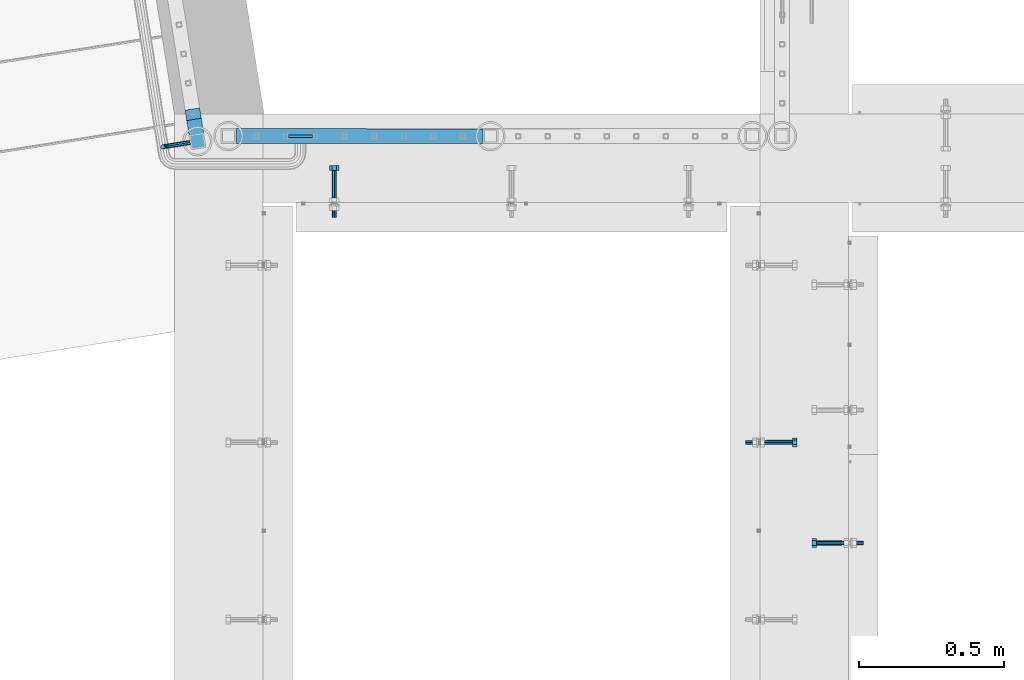
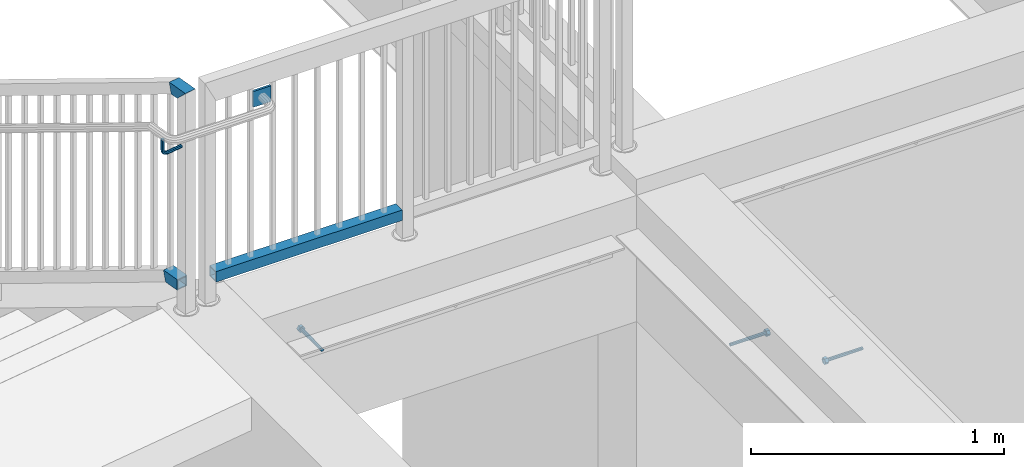
# One storey, part 425 of 975: 8 beams.
"""IFC2X3 building model written with IfcOpenShell, lengths in millimetres."""

from ifc_helpers import new_model, si_unit, frame, origin_with_axes, place, context, subcontext, project, spatial, faceted_brep, material, type_object, element, save


model = new_model("IFC2X3")

# Units and contexts
model_context = context("Model", 3, precision=1e-05, world=origin_with_axes())
body_context = subcontext(model_context, "Body", "Model", "MODEL_VIEW")
ifc_project = project(units=[si_unit("LENGTHUNIT", "METRE", prefix="MILLI"), si_unit("AREAUNIT", "SQUARE_METRE"), si_unit("VOLUMEUNIT", "CUBIC_METRE"), si_unit("MASSUNIT", "GRAM", prefix="KILO"), si_unit("TIMEUNIT", "SECOND"), si_unit("PLANEANGLEUNIT", "RADIAN"), si_unit("SOLIDANGLEUNIT", "STERADIAN"), si_unit("THERMODYNAMICTEMPERATUREUNIT", "DEGREE_CELSIUS"), si_unit("LUMINOUSINTENSITYUNIT", "LUMEN")], contexts=[model_context])

# Site, building, storey
site_placement = place(None, origin_with_axes())
site = spatial("IfcSite", under=ifc_project, at=site_placement, CompositionType="ELEMENT")
building_placement = place(site_placement, origin_with_axes())
building = spatial("IfcBuilding", under=site, at=building_placement, Name="Undefined", CompositionType="ELEMENT")
storey_placement = place(building_placement, origin_with_axes())
storey = spatial("IfcBuildingStorey", under=building, at=storey_placement, Name="Undefined", CompositionType="ELEMENT", Elevation=0.0)

# Beams
ifc_material_1 = material(Name="STEEL/A36")
beam_type_1 = type_object("IfcBeamType", PredefinedType="NOTDEFINED")
beam_1_placement = place(storey_placement, frame((54.8214659139176, 20650.6357570104, 4838.70005627134), z_axis=(0.0, 0.0, 1.0), x_axis=(-0.987688340611262, -0.156434464938429, 0.0)))
element("IfcBeam", 1, at=beam_1_placement, inside=storey, type_object=beam_type_1, material=ifc_material_1, Name="BRACKET", context=body_context, shape_type="Brep", body=[
    faceted_brep([(-4.22995071858168e-07, -7.93750000000728, 0.0), (-2.99107341561466e-07, -5.61266007567065, -5.61266007566792), (69.8503542524265, -5.61266011719636, -5.61266006824098), (69.8503542509172, -7.93750004153844, 7.13935150997713e-08), (-1.09139364212751e-11, 1.81898940354586e-12, -7.9375), (69.8503542548774, -4.15166141465306e-08, -7.93749999257489), (2.99089151667431e-07, 5.61266007567428, -5.61266007566792), (69.850354256834, 5.61266003415949, -5.61266006824462), (4.22980519942939e-07, 7.93750000001091, 0.0), (69.8503542571498, 7.93749995848702, 7.42329575587064e-09), (2.99089151667431e-07, 5.61266007567428, 5.61266007566792), (69.8503542556402, 5.61266003414494, 5.61266008309212), (-1.09139364212751e-11, 1.81898940354586e-12, 7.9375), (69.8503542531901, -4.1531166061759e-08, 7.93750000742511), (-2.99107341561466e-07, -5.61266007567065, 5.61266007566792), (69.8503542512333, -5.61266011720727, 5.61266008309485), (82.6080619660092, -1.59849150804803e-07, -5.39983437818319), (81.7183842570932, -5.61266021300253, -3.25196229146422), (79.5705123886862, -7.93750008296047, 1.9334595635828), (77.422640571061, -5.61266010424515, 7.11888139089478), (76.5329629847436, -6.04632077738643e-09, 9.26675341066039), (77.42264069366, 5.61266004711069, 7.11888132394142), (79.5705125620677, 7.93749991707227, 1.93345946889531), (81.7183843796927, 5.61265993835332, -3.2519623584185), (91.7796148150826, 5.61265980362077, 3.4707361335004), (93.4235246654027, -3.04684363072738e-07, 1.82682594388461), (87.8108651363229, 7.93749980671782, 7.4394864085989), (83.842115365278, 5.61265996114525, 11.4082366836983), (82.1982052921601, -8.1912730820477e-08, 13.0521468733186), (83.8421151424809, -5.61266019021059, 11.4082366837029), (87.8108648212394, -7.93750019330764, 7.43948640860435), (91.7796145922794, -5.61266034773871, 3.47073613349858), (98.5023147018187, 5.61265960524179, 13.5319656369056), (100.650186486849, -5.1793540478684e-07, 12.6422876414272), (93.316893218411, 7.93749964423841, 15.6798382195402), (88.1314716149859, 5.61265983456542, 17.8277107606718), (85.9835995402068, -1.93616870092228e-07, 18.7173886559558), (88.1314713252375, -5.61266031678679, 17.8277106604774), (93.3168928086452, -7.93750035579069, 15.6798380778428), (98.5023144120698, -5.6126605461177, 13.5319655367102), (100.86301410217, 5.61265937340795, 25.399995432489), (103.187853869874, -7.6714059105143e-07, 25.3999950007492), (95.2503540913781, 7.93749945436502, 25.3999962564121), (89.6376939508302, 5.61265968664884, 25.3999969898769), (87.3128538698681, -3.24151187669486e-07, 25.3999972032288), (89.6376936375721, -5.61266046470701, 25.399996771489), (95.2503537123291, -7.93750054566044, 25.3999959475659), (100.863013788912, -5.61266077794789, 25.3999952141021), (100.863020882074, -5.6126617210939, 76.2000018706158), (95.2503607602616, -7.93750153403744, 76.2000026040805), (103.187860917806, -1.69155464391224e-06, 76.2000016572638), (100.863021104872, 5.61265843026558, 76.2000020890027), (95.2503610753454, 7.93749846599167, 76.2000029129267), (89.6377009535329, 5.61265865304449, 76.2000036463905), (87.3128609178009, -1.37649476528168e-06, 76.2000038597416), (89.6377007307347, -5.61266149831135, 76.2000034280036)], [[[0, 1, 2, 3]], [[1, 4, 5, 2]], [[4, 6, 7, 5]], [[6, 8, 9, 7]], [[8, 10, 11, 9]], [[10, 12, 13, 11]], [[12, 14, 15, 13]], [[14, 0, 3, 15]], [[14, 12, 10, 8, 6, 4, 1, 0]], [[2, 5, 16, 17]], [[3, 2, 17, 18]], [[15, 3, 18, 19]], [[13, 15, 19, 20]], [[11, 13, 20, 21]], [[9, 11, 21, 22]], [[7, 9, 22, 23]], [[5, 7, 23, 16]], [[23, 24, 25, 16]], [[22, 26, 24, 23]], [[21, 27, 26, 22]], [[20, 28, 27, 21]], [[19, 29, 28, 20]], [[18, 30, 29, 19]], [[17, 31, 30, 18]], [[16, 25, 31, 17]], [[24, 32, 33, 25]], [[26, 34, 32, 24]], [[27, 35, 34, 26]], [[28, 36, 35, 27]], [[29, 37, 36, 28]], [[30, 38, 37, 29]], [[31, 39, 38, 30]], [[25, 33, 39, 31]], [[32, 40, 41, 33]], [[34, 42, 40, 32]], [[35, 43, 42, 34]], [[36, 44, 43, 35]], [[37, 45, 44, 36]], [[38, 46, 45, 37]], [[39, 47, 46, 38]], [[33, 41, 47, 39]], [[46, 47, 48, 49]], [[47, 41, 50, 48]], [[41, 40, 51, 50]], [[40, 42, 52, 51]], [[42, 43, 53, 52]], [[43, 44, 54, 53]], [[44, 45, 55, 54]], [[45, 46, 49, 55]], [[50, 51, 52, 53, 54, 55, 49, 48]]]),
])
ifc_material_2 = material()
beam_type_2 = type_object("IfcBeamType", Name="HSS2X2X.188_TUBES", PredefinedType="NOTDEFINED")
beam_2_placement = place(storey_placement, frame((186.288332017304, 20672.424971935, 4152.90002239251), z_axis=(4.97069999879329e-05, 0.999999998764607, 0.0), x_axis=(0.999999998764607, -4.97069999879304e-05, -1.40000005822416e-08)))
element("IfcBeam", 2, at=beam_2_placement, inside=storey, type_object=beam_type_2, material=ifc_material_2, Name="HANDRAIL", ObjectType="HSS2X2X.188_TUBES", context=body_context, shape_type="Brep", body=[
    faceted_brep([(25.4010274002821, 20.6374999999962, -20.6374999999789), (25.4010268224347, -20.6375000000035, -20.6375000000444), (876.518362135897, -20.6375000001299, -20.6374999995787), (876.518362755016, 20.6374999998698, -20.6374999996115), (25.3989752050193, -20.6375000000035, 20.6374999999534), (876.516310479488, -20.6375000001299, 20.6375000003572), (25.3989757828676, 20.6374999999971, 20.6375000000226), (876.516311098607, 20.6374999998707, 20.6375000003281), (25.4012641920428, 25.3999999999969, -25.399999999976), (25.3987391244552, 25.399999999996, 25.4000000000306), (876.516074440458, 25.3999999998705, 25.400000000318), (876.518599556039, 25.3999999998705, -25.3999999996086), (25.3987384132577, -25.4000000000042, 25.3999999999505), (876.516073678465, -25.4000000001288, 25.4000000003543), (25.4012634808457, -25.4000000000033, -25.400000000056), (876.518598794046, -25.4000000001297, -25.3999999995722)], [[[0, 1, 2, 3]], [[1, 4, 5, 2]], [[4, 6, 7, 5]], [[6, 0, 3, 7]], [[8, 9, 10, 11]], [[9, 12, 13, 10]], [[12, 14, 15, 13]], [[14, 8, 11, 15]], [[13, 15, 11, 10], [5, 7, 3, 2]], [[14, 12, 9, 8], [6, 4, 1, 0]]]),
])
beam_3_placement = place(storey_placement, frame((79.9089065875678, 20654.6092119886, 4152.89999210174), z_axis=(0.987688352468583, 0.156434390074216, -6.09999983468464e-08), x_axis=(-0.156434502935552, 0.987688334593108, 0.0)))
element("IfcBeam", 3, at=beam_3_placement, inside=storey, type_object=beam_type_2, material=ifc_material_2, Name="HANDRAIL", ObjectType="HSS2X2X.188_TUBES", context=body_context, shape_type="Brep", body=[
    faceted_brep([(25.3999997357314, 20.6374999999898, -20.6374999999998), (25.4000002641624, -20.6375000000153, -20.6374999999998), (100.375736823349, -20.637499999998, -20.6375000000148), (111.012663915226, 20.6375000000016, -20.6375000000157), (25.4000002641624, -20.6375000000153, 20.6374999999998), (100.375737142476, -20.637499999998, 20.6374999999903), (25.3999997357314, 20.6374999999898, 20.6374999999998), (111.012664234357, 20.6375000000016, 20.6374999999894), (25.4000003077635, 25.3999999999942, -25.3999999999996), (25.3999996747552, 25.3999999999905, 25.3999999999996), (112.240002012546, 25.4000000000024, 25.3999999999896), (112.240001619772, 25.4000000000024, -25.400000000016), (25.4000003251349, -25.4000000000124, 25.3999999999996), (99.1483994379269, -25.3999999999987, 25.3999999999901), (25.4000003077854, -25.4000000000087, -25.3999999999996), (99.1483990451525, -25.3999999999987, -25.4000000000146)], [[[0, 1, 2, 3]], [[1, 4, 5, 2]], [[4, 6, 7, 5]], [[6, 0, 3, 7]], [[8, 9, 10, 11]], [[9, 12, 13, 10]], [[12, 14, 15, 13]], [[14, 8, 11, 15]], [[13, 15, 11, 10], [5, 7, 3, 2]], [[14, 12, 9, 8], [6, 4, 1, 0]]]),
])
beam_4_placement = place(storey_placement, frame((79.9089713856818, 20654.6092409208, 5079.99999210166), z_axis=(0.987688199802292, 0.156435353968682, 0.0), x_axis=(-0.156435353968642, 0.987688199802032, 7.25999996843755e-07)))
element("IfcBeam", 4, at=beam_4_placement, inside=storey, type_object=beam_type_2, material=ifc_material_2, Name="HANDRAIL", ObjectType="HSS2X2X.188_TUBES", context=body_context, shape_type="Brep", body=[
    faceted_brep([(-20.6375220683622, 20.6375000000126, -20.6374999999962), (20.6375002484456, -20.637500000008, -20.6374999999998), (64.3357161775057, -20.6375000000317, -20.6374999999998), (74.9726787480031, 20.6374999999744, -20.6374999999898), (20.6374851600922, -20.6375000000144, 20.637499999998), (64.3356988180385, -20.6375000000317, 20.6375000000007), (-20.6375002658751, 20.637500000008, 20.6374999999998), (74.9726613885359, 20.6374999999744, 20.6375000000112), (-25.4000229024168, 25.400000000016, -25.3999999999955), (-25.4000003252186, 25.4000000000087, 25.3999999999996), (76.2000012205863, 25.3999999999751, 25.4000000000128), (76.2000225860793, 25.3999999999751, -25.3999999999887), (25.4000003251349, -25.4000000000124, 25.3999999999996), (63.108354979966, -25.4000000000324, 25.4000000000001), (25.4000003077854, -25.4000000000087, -25.3999999999996), (63.1083763454626, -25.4000000000324, -25.400000000001)], [[[0, 1, 2, 3]], [[1, 4, 5, 2]], [[4, 6, 7, 5]], [[6, 0, 3, 7]], [[8, 9, 10, 11]], [[9, 12, 13, 10]], [[12, 14, 15, 13]], [[14, 8, 11, 15]], [[13, 15, 11, 10], [5, 7, 3, 2]], [[14, 12, 9, 8], [6, 4, 1, 0]]]),
])
beam_type_3 = type_object("IfcBeamType", PredefinedType="NOTDEFINED")
beam_5_placement = place(storey_placement, frame((392.771996097373, 20672.3889447702, 4933.95004945535), z_axis=(0.0, 0.0, 1.0), x_axis=(1.0, 0.0, 0.0)))
element("IfcBeam", 5, at=beam_5_placement, inside=storey, type_object=beam_type_3, material=ifc_material_1, Name="PLATE", context=body_context, shape_type="Brep", body=[
    faceted_brep([(5.45696821063757e-12, 4.762500000008, -38.1000000000004), (5.45696821063757e-12, 4.762500000008, 38.1000000000004), (82.5500029908536, 4.76250000012442, 38.1000000000113), (82.5500029908522, 4.76250000012442, -38.0999999999885), (-3.63797880709171e-12, -4.76250000000437, 38.1000000000004), (82.5500029908539, -4.76249999987704, 38.1000000000113), (-3.63797880709171e-12, -4.76250000000437, -38.1000000000004), (82.5500029908525, -4.76249999987704, -38.0999999999885)], [[[0, 1, 2, 3]], [[1, 4, 5, 2]], [[4, 6, 7, 5]], [[6, 0, 3, 7]], [[5, 7, 3, 2]], [[6, 4, 1, 0]]]),
])
ifc_material_3 = material(Name="STEEL/F1554-36")
beam_type_4 = type_object("IfcBeamType", PredefinedType="NOTDEFINED")
beam_6_placement = place(storey_placement, frame((2298.70035269796, 19272.2499761124, 3886.2), z_axis=(0.0, 0.0, -1.0), x_axis=(-0.999999999999998, 6.90000001668524e-08, 0.0)))
element("IfcBeam", 6, at=beam_6_placement, inside=storey, type_object=beam_type_4, material=ifc_material_3, Name="HEADED_ANCHOR_BOLT", context=body_context, shape_type="Brep", body=[
    faceted_brep([(88.9000000184824, 7.94000001861696, -13.7499999799138), (88.8999999527368, 15.8800000758411, 2.00943759409711e-08), (104.774999952569, 15.8800001213949, 6.97191353538074e-08), (104.775000018315, 7.94000006417082, -13.7499999302891), (88.900000064019, -7.94000009583215, -13.7499999799147), (104.775000063852, -7.9400000502792, -13.74999993029), (88.9000000438027, -15.880000153059, 2.00925569515675e-08), (104.775000043643, -15.8800001075042, 6.9716406869702e-08), (88.8999999780608, -7.94000009583488, 13.7500000200998), (104.774999977893, -7.94000005028101, 13.7500000697237), (88.8999999325279, 7.94000001861514, 13.7500000201007), (104.774999932361, 7.940000064169, 13.7500000697246), (88.9000000119959, 3.78780480527439, -7.86545778426807), (88.8999999957159, 6.82538844544797, -5.4430656647246), (88.8999999799416, 8.51112018845743, -1.94260763148395), (88.8999999677944, 8.51112018845652, 1.94260767167179), (88.8999999616899, 6.82538844544615, 5.44306570491244), (88.8999999628249, 3.78780480527257, 7.86545782445592), (88.8999999709849, -3.86089595849626e-08, 8.72999956233434), (88.8999999845473, -3.7878048824914, 7.8654578244541), (88.9000000008309, -6.82538852266407, 5.44306570491153), (88.9000000166052, -8.51112026567444, 1.94260767166998), (88.9000000287488, -8.51112026567353, -1.94260763148577), (88.9000000348606, -6.82538852266407, -5.44306566472642), (88.9000000337182, -3.78780488248958, -7.86545778426898), (88.9000000255583, -3.86080500902608e-08, -8.72999952214832), (104.775000025395, 6.94581103743985e-09, -8.72999947252447), (104.775000011829, 3.78780485082825, -7.86545773464422), (104.774999995549, 6.82538849100092, -5.44306561510075), (104.774999979774, 8.51112023401038, -1.9426075818601), (104.774999967627, 8.51112023401038, 1.94260772129564), (104.774999961523, 6.82538849100092, 5.44306575453629), (104.774999962658, 3.78780485082643, 7.86545787407977), (104.774999970818, 6.94399204803631e-09, 8.7299996119591), (104.77499998438, -3.78780483693754, 7.86545787407886), (104.775000000664, -6.82538847711112, 5.44306575453538), (104.775000016438, -8.51112022012057, 1.94260772129473), (104.775000028581, -8.51112022012057, -1.94260758186101), (104.775000034693, -6.82538847711021, -5.44306561510166), (104.775000033551, -3.78780483693663, -7.86545773464422), (-2.99107341561466e-07, -5.61266007567065, 5.61266007566792), (-4.22995071858168e-07, -7.93750000000728, 0.0), (104.774999998088, -7.93749999999, -4.45652403868735e-11), (104.774999998088, -5.61266007565791, 5.61266007562426), (-1.09139364212751e-11, 1.81898940354586e-12, 7.9375), (104.774999998095, 1.18234311230481e-11, 7.93749999995816), (2.99089151667431e-07, 5.61266007567428, 5.61266007566792), (104.774999998102, 5.61266007568065, 5.61266007562517), (4.22980519942939e-07, 7.93750000001091, 0.0), (104.77499999811, 7.93750000001364, -4.36557456851006e-11), (2.99089151667431e-07, 5.61266007567428, -5.61266007566792), (104.774999998102, 5.61266007568156, -5.61266007571339), (-1.09139364212751e-11, 1.81898940354586e-12, -7.9375), (104.774999998099, 1.2732925824821e-11, -7.93750000004547), (-73.0249999592124, 5.05157065939329, -5.0515715445581), (-73.0249999269472, -1.85405951924622e-07, -7.14400069976364), (-73.0249999328516, -5.0515710302052, -5.05157154455992), (-73.0249999734697, -7.14400018541073, -6.9975976657588e-07), (-73.0250000250016, -5.05157103020611, 5.05157014504039), (-73.0250000572705, -1.85406861419324e-07, 7.1439993002441), (-73.0250000513661, 5.05157065939238, 5.05157014503948), (-73.025000010748, 7.14399981459792, -6.99758857081179e-07), (0.00625003290042514, 5.05157085007795, -5.05157087849238), (0.00625006516929716, 5.27870724909008e-09, -7.1440000336961), (0.00625005926485755, -5.05157083952145, -5.05157087849329), (0.00625001864682417, -7.14399999472516, -3.36940502165817e-08), (0.00624996711121639, -5.05157083952145, 5.05157081110519), (0.00624993484598235, 5.2777977543883e-09, 7.14399996631164), (0.00624994074678398, 5.05157085007704, 5.05157081110701), (0.00624998136845534, 7.14400000528167, -3.36922312271781e-08), (-2.99107341561466e-07, -5.61266007567065, -5.61266007566792), (104.774999998092, -5.612660075657, -5.6126600757143)], [[[0, 1, 2, 3]], [[4, 0, 3, 5]], [[6, 4, 5, 7]], [[8, 6, 7, 9]], [[10, 8, 9, 11]], [[0, 4, 6, 8, 10, 1], [12, 13, 14, 15, 16, 17, 18, 19, 20, 21, 22, 23, 24, 25]], [[12, 25, 26, 27]], [[13, 12, 27, 28]], [[14, 13, 28, 29]], [[15, 14, 29, 30]], [[16, 15, 30, 31]], [[17, 16, 31, 32]], [[18, 17, 32, 33]], [[19, 18, 33, 34]], [[20, 19, 34, 35]], [[21, 20, 35, 36]], [[22, 21, 36, 37]], [[23, 22, 37, 38]], [[24, 23, 38, 39]], [[25, 24, 39, 26]], [[9, 7, 5, 3, 2, 11], [38, 37, 36, 35, 34, 33, 32, 31, 30, 29, 28, 27, 26, 39]], [[1, 10, 11, 2]], [[40, 41, 42, 43]], [[44, 40, 43, 45]], [[46, 44, 45, 47]], [[48, 46, 47, 49]], [[50, 48, 49, 51]], [[52, 50, 51, 53]], [[54, 55, 56, 57, 58, 59, 60, 61]], [[55, 54, 62, 63]], [[56, 55, 63, 64]], [[57, 56, 64, 65]], [[58, 57, 65, 66]], [[59, 58, 66, 67]], [[60, 59, 67, 68]], [[61, 60, 68, 69]], [[54, 61, 69, 62]], [[40, 44, 46, 48, 50, 52, 70, 41], [68, 67, 66, 65, 64, 63, 62, 69]], [[41, 70, 71, 42]], [[53, 51, 49, 47, 45, 43, 42, 71]], [[70, 52, 53, 71]]]),
])
beam_7_placement = place(storey_placement, frame((550.862524737206, 20466.0499999496, 3835.4), z_axis=(0.0, 0.0, 1.0), x_axis=(0.0, 1.0, 0.0)))
element("IfcBeam", 7, at=beam_7_placement, inside=storey, type_object=beam_type_4, material=ifc_material_3, Name="HEADED_ANCHOR_BOLT", context=body_context, shape_type="Brep", body=[
    faceted_brep([(88.9000000184824, 7.94000001861696, -13.7499999799138), (88.8999999527368, 15.8800000758411, 2.00943759409711e-08), (104.774999952569, 15.8800001213949, 6.97191353538074e-08), (104.775000018315, 7.94000006417082, -13.7499999302891), (88.900000064019, -7.94000009583215, -13.7499999799147), (104.775000063852, -7.9400000502792, -13.74999993029), (88.9000000438027, -15.880000153059, 2.00925569515675e-08), (104.775000043643, -15.8800001075042, 6.9716406869702e-08), (88.8999999780608, -7.94000009583488, 13.7500000200998), (104.774999977893, -7.94000005028101, 13.7500000697237), (88.8999999325279, 7.94000001861514, 13.7500000201007), (104.774999932361, 7.940000064169, 13.7500000697246), (88.9000000119959, 3.78780480527439, -7.86545778426807), (88.8999999957159, 6.82538844544797, -5.4430656647246), (88.8999999799416, 8.51112018845743, -1.94260763148395), (88.8999999677944, 8.51112018845652, 1.94260767167179), (88.8999999616899, 6.82538844544615, 5.44306570491244), (88.8999999628249, 3.78780480527257, 7.86545782445592), (88.8999999709849, -3.86089595849626e-08, 8.72999956233434), (88.8999999845473, -3.7878048824914, 7.8654578244541), (88.9000000008309, -6.82538852266407, 5.44306570491153), (88.9000000166052, -8.51112026567444, 1.94260767166998), (88.9000000287488, -8.51112026567353, -1.94260763148577), (88.9000000348606, -6.82538852266407, -5.44306566472642), (88.9000000337182, -3.78780488248958, -7.86545778426898), (88.9000000255583, -3.86080500902608e-08, -8.72999952214832), (104.775000025395, 6.94581103743985e-09, -8.72999947252447), (104.775000011829, 3.78780485082825, -7.86545773464422), (104.774999995549, 6.82538849100092, -5.44306561510075), (104.774999979774, 8.51112023401038, -1.9426075818601), (104.774999967627, 8.51112023401038, 1.94260772129564), (104.774999961523, 6.82538849100092, 5.44306575453629), (104.774999962658, 3.78780485082643, 7.86545787407977), (104.774999970818, 6.94399204803631e-09, 8.7299996119591), (104.77499998438, -3.78780483693754, 7.86545787407886), (104.775000000664, -6.82538847711112, 5.44306575453538), (104.775000016438, -8.51112022012057, 1.94260772129473), (104.775000028581, -8.51112022012057, -1.94260758186101), (104.775000034693, -6.82538847711021, -5.44306561510166), (104.775000033551, -3.78780483693663, -7.86545773464422), (-2.99107341561466e-07, -5.61266007567065, 5.61266007566792), (-4.22995071858168e-07, -7.93750000000728, 0.0), (104.774999998088, -7.93749999999, -4.45652403868735e-11), (104.774999998088, -5.61266007565791, 5.61266007562426), (-1.09139364212751e-11, 1.81898940354586e-12, 7.9375), (104.774999998095, 1.18234311230481e-11, 7.93749999995816), (2.99089151667431e-07, 5.61266007567428, 5.61266007566792), (104.774999998102, 5.61266007568065, 5.61266007562517), (4.22980519942939e-07, 7.93750000001091, 0.0), (104.77499999811, 7.93750000001364, -4.36557456851006e-11), (2.99089151667431e-07, 5.61266007567428, -5.61266007566792), (104.774999998102, 5.61266007568156, -5.61266007571339), (-1.09139364212751e-11, 1.81898940354586e-12, -7.9375), (104.774999998099, 1.2732925824821e-11, -7.93750000004547), (-73.0249999592124, 5.05157065939329, -5.0515715445581), (-73.0249999269472, -1.85405951924622e-07, -7.14400069976364), (-73.0249999328516, -5.0515710302052, -5.05157154455992), (-73.0249999734697, -7.14400018541073, -6.9975976657588e-07), (-73.0250000250016, -5.05157103020611, 5.05157014504039), (-73.0250000572705, -1.85406861419324e-07, 7.1439993002441), (-73.0250000513661, 5.05157065939238, 5.05157014503948), (-73.025000010748, 7.14399981459792, -6.99758857081179e-07), (0.00625003290042514, 5.05157085007795, -5.05157087849238), (0.00625006516929716, 5.27870724909008e-09, -7.1440000336961), (0.00625005926485755, -5.05157083952145, -5.05157087849329), (0.00625001864682417, -7.14399999472516, -3.36940502165817e-08), (0.00624996711121639, -5.05157083952145, 5.05157081110519), (0.00624993484598235, 5.2777977543883e-09, 7.14399996631164), (0.00624994074678398, 5.05157085007704, 5.05157081110701), (0.00624998136845534, 7.14400000528167, -3.36922312271781e-08), (-2.99107341561466e-07, -5.61266007567065, -5.61266007566792), (104.774999998092, -5.612660075657, -5.6126600757143)], [[[0, 1, 2, 3]], [[4, 0, 3, 5]], [[6, 4, 5, 7]], [[8, 6, 7, 9]], [[10, 8, 9, 11]], [[0, 4, 6, 8, 10, 1], [12, 13, 14, 15, 16, 17, 18, 19, 20, 21, 22, 23, 24, 25]], [[12, 25, 26, 27]], [[13, 12, 27, 28]], [[14, 13, 28, 29]], [[15, 14, 29, 30]], [[16, 15, 30, 31]], [[17, 16, 31, 32]], [[18, 17, 32, 33]], [[19, 18, 33, 34]], [[20, 19, 34, 35]], [[21, 20, 35, 36]], [[22, 21, 36, 37]], [[23, 22, 37, 38]], [[24, 23, 38, 39]], [[25, 24, 39, 26]], [[9, 7, 5, 3, 2, 11], [38, 37, 36, 35, 34, 33, 32, 31, 30, 29, 28, 27, 26, 39]], [[1, 10, 11, 2]], [[40, 41, 42, 43]], [[44, 40, 43, 45]], [[46, 44, 45, 47]], [[48, 46, 47, 49]], [[50, 48, 49, 51]], [[52, 50, 51, 53]], [[54, 55, 56, 57, 58, 59, 60, 61]], [[55, 54, 62, 63]], [[56, 55, 63, 64]], [[57, 56, 64, 65]], [[58, 57, 65, 66]], [[59, 58, 66, 67]], [[60, 59, 67, 68]], [[61, 60, 68, 69]], [[54, 61, 69, 62]], [[40, 44, 46, 48, 50, 52, 70, 41], [68, 67, 66, 65, 64, 63, 62, 69]], [[41, 70, 71, 42]], [[53, 51, 49, 47, 45, 43, 42, 71]], [[70, 52, 53, 71]]]),
])
beam_8_placement = place(storey_placement, frame((2038.35000477327, 19618.324926606, 3835.4), z_axis=(0.0, 0.0, 1.0), x_axis=(1.0, 0.0, 0.0)))
element("IfcBeam", 8, at=beam_8_placement, inside=storey, type_object=beam_type_4, material=ifc_material_3, Name="HEADED_ANCHOR_BOLT", context=body_context, shape_type="Brep", body=[
    faceted_brep([(88.9000000184824, 7.94000001861696, -13.7499999799138), (88.8999999527368, 15.8800000758411, 2.00943759409711e-08), (104.774999952569, 15.8800001213949, 6.97191353538074e-08), (104.775000018315, 7.94000006417082, -13.7499999302891), (88.900000064019, -7.94000009583215, -13.7499999799147), (104.775000063852, -7.9400000502792, -13.74999993029), (88.9000000438027, -15.880000153059, 2.00925569515675e-08), (104.775000043643, -15.8800001075042, 6.9716406869702e-08), (88.8999999780608, -7.94000009583488, 13.7500000200998), (104.774999977893, -7.94000005028101, 13.7500000697237), (88.8999999325279, 7.94000001861514, 13.7500000201007), (104.774999932361, 7.940000064169, 13.7500000697246), (88.9000000119959, 3.78780480527439, -7.86545778426807), (88.8999999957159, 6.82538844544797, -5.4430656647246), (88.8999999799416, 8.51112018845743, -1.94260763148395), (88.8999999677944, 8.51112018845652, 1.94260767167179), (88.8999999616899, 6.82538844544615, 5.44306570491244), (88.8999999628249, 3.78780480527257, 7.86545782445592), (88.8999999709849, -3.86089595849626e-08, 8.72999956233434), (88.8999999845473, -3.7878048824914, 7.8654578244541), (88.9000000008309, -6.82538852266407, 5.44306570491153), (88.9000000166052, -8.51112026567444, 1.94260767166998), (88.9000000287488, -8.51112026567353, -1.94260763148577), (88.9000000348606, -6.82538852266407, -5.44306566472642), (88.9000000337182, -3.78780488248958, -7.86545778426898), (88.9000000255583, -3.86080500902608e-08, -8.72999952214832), (104.775000025395, 6.94581103743985e-09, -8.72999947252447), (104.775000011829, 3.78780485082825, -7.86545773464422), (104.774999995549, 6.82538849100092, -5.44306561510075), (104.774999979774, 8.51112023401038, -1.9426075818601), (104.774999967627, 8.51112023401038, 1.94260772129564), (104.774999961523, 6.82538849100092, 5.44306575453629), (104.774999962658, 3.78780485082643, 7.86545787407977), (104.774999970818, 6.94399204803631e-09, 8.7299996119591), (104.77499998438, -3.78780483693754, 7.86545787407886), (104.775000000664, -6.82538847711112, 5.44306575453538), (104.775000016438, -8.51112022012057, 1.94260772129473), (104.775000028581, -8.51112022012057, -1.94260758186101), (104.775000034693, -6.82538847711021, -5.44306561510166), (104.775000033551, -3.78780483693663, -7.86545773464422), (-2.99107341561466e-07, -5.61266007567065, 5.61266007566792), (-4.22995071858168e-07, -7.93750000000728, 0.0), (104.774999998088, -7.93749999999, -4.45652403868735e-11), (104.774999998088, -5.61266007565791, 5.61266007562426), (-1.09139364212751e-11, 1.81898940354586e-12, 7.9375), (104.774999998095, 1.18234311230481e-11, 7.93749999995816), (2.99089151667431e-07, 5.61266007567428, 5.61266007566792), (104.774999998102, 5.61266007568065, 5.61266007562517), (4.22980519942939e-07, 7.93750000001091, 0.0), (104.77499999811, 7.93750000001364, -4.36557456851006e-11), (2.99089151667431e-07, 5.61266007567428, -5.61266007566792), (104.774999998102, 5.61266007568156, -5.61266007571339), (-1.09139364212751e-11, 1.81898940354586e-12, -7.9375), (104.774999998099, 1.2732925824821e-11, -7.93750000004547), (-73.0249999592124, 5.05157065939329, -5.0515715445581), (-73.0249999269472, -1.85405951924622e-07, -7.14400069976364), (-73.0249999328516, -5.0515710302052, -5.05157154455992), (-73.0249999734697, -7.14400018541073, -6.9975976657588e-07), (-73.0250000250016, -5.05157103020611, 5.05157014504039), (-73.0250000572705, -1.85406861419324e-07, 7.1439993002441), (-73.0250000513661, 5.05157065939238, 5.05157014503948), (-73.025000010748, 7.14399981459792, -6.99758857081179e-07), (0.00625003290042514, 5.05157085007795, -5.05157087849238), (0.00625006516929716, 5.27870724909008e-09, -7.1440000336961), (0.00625005926485755, -5.05157083952145, -5.05157087849329), (0.00625001864682417, -7.14399999472516, -3.36940502165817e-08), (0.00624996711121639, -5.05157083952145, 5.05157081110519), (0.00624993484598235, 5.2777977543883e-09, 7.14399996631164), (0.00624994074678398, 5.05157085007704, 5.05157081110701), (0.00624998136845534, 7.14400000528167, -3.36922312271781e-08), (-2.99107341561466e-07, -5.61266007567065, -5.61266007566792), (104.774999998092, -5.612660075657, -5.6126600757143)], [[[0, 1, 2, 3]], [[4, 0, 3, 5]], [[6, 4, 5, 7]], [[8, 6, 7, 9]], [[10, 8, 9, 11]], [[0, 4, 6, 8, 10, 1], [12, 13, 14, 15, 16, 17, 18, 19, 20, 21, 22, 23, 24, 25]], [[12, 25, 26, 27]], [[13, 12, 27, 28]], [[14, 13, 28, 29]], [[15, 14, 29, 30]], [[16, 15, 30, 31]], [[17, 16, 31, 32]], [[18, 17, 32, 33]], [[19, 18, 33, 34]], [[20, 19, 34, 35]], [[21, 20, 35, 36]], [[22, 21, 36, 37]], [[23, 22, 37, 38]], [[24, 23, 38, 39]], [[25, 24, 39, 26]], [[9, 7, 5, 3, 2, 11], [38, 37, 36, 35, 34, 33, 32, 31, 30, 29, 28, 27, 26, 39]], [[1, 10, 11, 2]], [[40, 41, 42, 43]], [[44, 40, 43, 45]], [[46, 44, 45, 47]], [[48, 46, 47, 49]], [[50, 48, 49, 51]], [[52, 50, 51, 53]], [[54, 55, 56, 57, 58, 59, 60, 61]], [[55, 54, 62, 63]], [[56, 55, 63, 64]], [[57, 56, 64, 65]], [[58, 57, 65, 66]], [[59, 58, 66, 67]], [[60, 59, 67, 68]], [[61, 60, 68, 69]], [[54, 61, 69, 62]], [[40, 44, 46, 48, 50, 52, 70, 41], [68, 67, 66, 65, 64, 63, 62, 69]], [[41, 70, 71, 42]], [[53, 51, 49, 47, 45, 43, 42, 71]], [[70, 52, 53, 71]]]),
])

save(model, "model.ifc")
